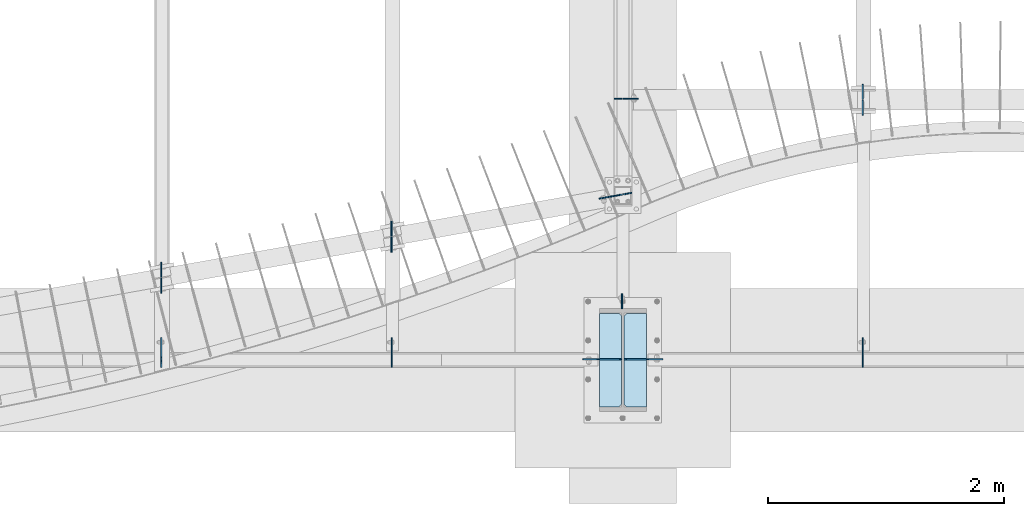
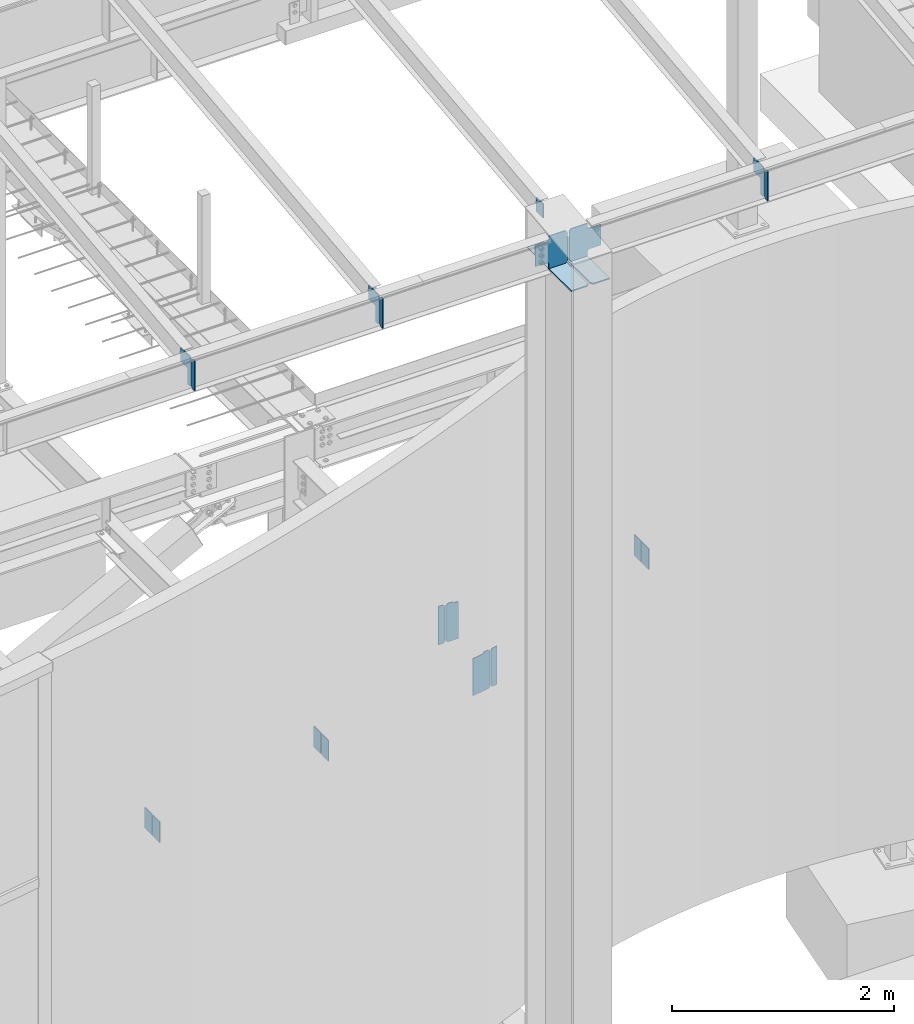
# One storey, part 986 of 1179: 21 plates, 6 elements without a shape of their own.
"""IFC2X3 building model written with IfcOpenShell, lengths in millimetres."""

import ifcopenshell
import ifcopenshell.guid

model = None  # the IFC model being written
_history = None  # IfcOwnerHistory: only IFC2X3 demands one
_inside = {}  # id of a spatial element -> (the spatial element, [elements in it])
_under = {}  # id of a project, library or spatial element -> (it, [spatial elements below it])
_declared = {}  # id of a project -> (the project, [libraries it declares])
_typed = {}  # id of a type object -> (the type object, [elements of that type])
_made_of = {}  # id of a material, layer set ... -> (it, [elements and type objects made of it])


def new_model(schema):
    """Start an empty IFC model of exactly this schema.

    Asked for "IFC4X3", IfcOpenShell would pick the latest addendum, in which some entities
    have other attributes; the version numbers below select the first issue.
    IFC2X3 requires an IfcOwnerHistory on every rooted entity: one is made here for all.
    """
    global model, _history
    if schema == "IFC4X3":
        model = ifcopenshell.file(schema_version=(4, 3, 0, 0))
    else:
        model = ifcopenshell.file(schema=schema)
    _inside.clear()
    _under.clear()
    _declared.clear()
    _typed.clear()
    _made_of.clear()
    _history = None
    if model.schema == "IFC2X3":
        org = make("IfcOrganization", Name="unknown")
        user = make(
            "IfcPersonAndOrganization",
            ThePerson=make("IfcPerson", FamilyName="unknown"),
            TheOrganization=org,
        )
        app = make(
            "IfcApplication",
            ApplicationDeveloper=org,
            Version="unknown",
            ApplicationFullName="unknown",
            ApplicationIdentifier="unknown",
        )
        _history = make(
            "IfcOwnerHistory",
            OwningUser=user,
            OwningApplication=app,
            ChangeAction="ADDED",
            CreationDate=0,
        )
    return model


def make(cls, **values):
    """One entity of the class cls with the attributes given. An attribute that is None is left unset."""
    return model.create_entity(
        cls, **{name: value for name, value in values.items() if value is not None}
    )


def rooted(cls, **values):
    """An entity with a GlobalId (a new one), such as an element, a storey or a relation."""
    return make(cls, GlobalId=ifcopenshell.guid.new(), OwnerHistory=_history, **values)


def si_unit(unit_type, name, prefix=None):
    """IfcSIUnit, for example si_unit("LENGTHUNIT", "METRE", prefix="MILLI")."""
    return make("IfcSIUnit", UnitType=unit_type, Prefix=prefix, Name=name)


def assignment(units):
    """IfcUnitAssignment: the units of a project."""
    return None if units is None else make("IfcUnitAssignment", Units=units)


def point(xyz):
    """IfcCartesianPoint."""
    return None if xyz is None else make("IfcCartesianPoint", Coordinates=xyz)


def direction(xyz):
    """IfcDirection."""
    return None if xyz is None else make("IfcDirection", DirectionRatios=xyz)


def frame(location, z_axis=None, x_axis=None):
    """IfcAxis2Placement3D, a coordinate frame: its origin and axes. An axis left out is left unset."""
    return make(
        "IfcAxis2Placement3D",
        Location=point(location),
        Axis=direction(z_axis),
        RefDirection=direction(x_axis),
    )


def origin_with_axes():
    """The frame at (0, 0, 0) with the z axis (0, 0, 1) and the x axis (1, 0, 0) written out."""
    return frame((0.0, 0.0, 0.0), z_axis=(0.0, 0.0, 1.0), x_axis=(1.0, 0.0, 0.0))


def place(relative_to, where):
    """IfcLocalPlacement: puts the frame where relative to a parent placement (None: the world)."""
    return make(
        "IfcLocalPlacement", PlacementRelTo=relative_to, RelativePlacement=where
    )


def context(
    kind, dimensions, precision=None, world=None, true_north=None, identifier=None
):
    """IfcGeometricRepresentationContext, for example the 3D "Model" context."""
    return make(
        "IfcGeometricRepresentationContext",
        ContextIdentifier=identifier,
        ContextType=kind,
        CoordinateSpaceDimension=dimensions,
        Precision=precision,
        WorldCoordinateSystem=world,
        TrueNorth=true_north,
    )


def subcontext(parent, identifier, kind, view, scale=None):
    """IfcGeometricRepresentationSubContext, for example "Body" below "Model"."""
    return make(
        "IfcGeometricRepresentationSubContext",
        ContextIdentifier=identifier,
        ContextType=kind,
        ParentContext=parent,
        TargetScale=scale,
        TargetView=view,
    )


def project(units=None, contexts=None):
    """IfcProject with its units and contexts."""
    return rooted(
        "IfcProject",
        Name="project",
        RepresentationContexts=contexts,
        UnitsInContext=assignment(units),
    )


def spatial(cls, under=None, at=None, **own):
    """A site, building, storey or space (cls), placed at a placement, below another one or the project."""
    s = rooted(cls, ObjectPlacement=at, **own)
    if under is not None:
        _under.setdefault(under.id(), (under, []))[1].append(s)
    return s


def faces_of(points, faces, orient=None, outer=None):
    """IfcFace entities. A face is a list of loops; a loop is a list of indices into points, from 0.

    orient and outer hold one flag for each loop. By default every Orientation is true, the
    first loop of a face is its IfcFaceOuterBound and the others are IfcFaceBound.
    """
    made = []
    for i, loops in enumerate(faces):
        bounds = []
        for j, loop in enumerate(loops):
            is_outer = j == 0 if outer is None else outer[i][j]
            bounds.append(
                make(
                    "IfcFaceOuterBound" if is_outer else "IfcFaceBound",
                    Bound=make("IfcPolyLoop", Polygon=[points[k] for k in loop]),
                    Orientation=True if orient is None else orient[i][j],
                )
            )
        made.append(make("IfcFace", Bounds=bounds))
    return made


def faceted_brep(points, faces, orient=None, outer=None, voids=None):
    """IfcFacetedBrep: a solid bounded by flat faces; with voids (closed shells), ...WithVoids."""
    shared = [point(p) for p in points]
    hull = make("IfcClosedShell", CfsFaces=faces_of(shared, faces, orient, outer))
    if voids is None:
        return make("IfcFacetedBrep", Outer=hull)
    return make(
        "IfcFacetedBrepWithVoids",
        Outer=hull,
        Voids=[
            make(cls, CfsFaces=faces_of(shared, fs, o, b)) for cls, fs, o, b in voids
        ],
    )


def shape(context_of_items, identifier, shape_type, items):
    """IfcShapeRepresentation: the items that make up one representation, for example the "Body"."""
    return make(
        "IfcShapeRepresentation",
        ContextOfItems=context_of_items,
        RepresentationIdentifier=identifier,
        RepresentationType=shape_type,
        Items=items,
    )


def material(Name=None, Category=None):
    """IfcMaterial."""
    return make("IfcMaterial", Name=Name, Category=Category)


def made_of(thing, what):
    """Note that an element or type object is made of a material, layer set ...; save() writes the relation."""
    if what is not None:
        _made_of.setdefault(what.id(), (what, []))[1].append(thing)
    return thing


def type_object(cls, material=None, **own):
    """A type object (cls), such as IfcWallType, which elements share."""
    return made_of(rooted(cls, **own), material)


def element(
    cls,
    number,
    at=None,
    inside=None,
    cuts=None,
    type_object=None,
    material=None,
    context=None,
    identifier="Body",
    shape_type=None,
    held_by="IfcProductDefinitionShape",
    body=None,
    shapes=None,
    **own,
):
    """One element of the class cls, such as IfcWall. Its Tag is "e" and its number.

    at: its placement. inside: the storey or other place that contains it. cuts: it is an
    opening in that element (IfcRelVoidsElement). A single representation is given by context,
    identifier, shape_type and body (its items); several are given by shapes. held_by: the class
    of the entity that holds the representations. save() writes the other relations.
    """
    e = rooted(cls, Tag="e%d" % number, ObjectPlacement=at, **own)
    if body is not None:
        shapes = [shape(context, identifier, shape_type, body)]
    if shapes is not None:
        e.Representation = make(held_by, Representations=shapes)
    if inside is not None:
        _inside.setdefault(inside.id(), (inside, []))[1].append(e)
    if cuts is not None:
        rooted(
            "IfcRelVoidsElement", RelatingBuildingElement=cuts, RelatedOpeningElement=e
        )
    if type_object is not None:
        _typed.setdefault(type_object.id(), (type_object, []))[1].append(e)
    return made_of(e, material)


def aggregate(whole, parts):
    """IfcRelAggregates: a whole, such as a stair, and the parts it consists of."""
    return rooted("IfcRelAggregates", RelatingObject=whole, RelatedObjects=parts)


def save(model, path):
    """Write the relations noted so far, then the file.

    IfcRelAggregates (storeys below a building ...), IfcRelContainedInSpatialStructure (elements
    in a storey), IfcRelDefinesByType, IfcRelAssociatesMaterial and IfcRelDeclares: one each for
    every whole, place, type object, material and project.
    """
    for whole, parts in _under.values():
        aggregate(whole, parts)
    for where, things in _inside.values():
        rooted(
            "IfcRelContainedInSpatialStructure",
            RelatedElements=things,
            RelatingStructure=where,
        )
    for kind, things in _typed.values():
        rooted("IfcRelDefinesByType", RelatedObjects=things, RelatingType=kind)
    for what, things in _made_of.values():
        rooted("IfcRelAssociatesMaterial", RelatedObjects=things, RelatingMaterial=what)
    for by, libraries in _declared.values():
        rooted("IfcRelDeclares", RelatingContext=by, RelatedDefinitions=libraries)
    model.write(path)


model = new_model("IFC2X3")

# Units and contexts
model_context = context("Model", 3, precision=1e-05, world=origin_with_axes())
body_context = subcontext(model_context, "Body", "Model", "MODEL_VIEW")
ifc_project = project(units=[si_unit("LENGTHUNIT", "METRE", prefix="MILLI"), si_unit("AREAUNIT", "SQUARE_METRE"), si_unit("VOLUMEUNIT", "CUBIC_METRE"), si_unit("MASSUNIT", "GRAM", prefix="KILO"), si_unit("TIMEUNIT", "SECOND"), si_unit("PLANEANGLEUNIT", "RADIAN"), si_unit("SOLIDANGLEUNIT", "STERADIAN"), si_unit("THERMODYNAMICTEMPERATUREUNIT", "DEGREE_CELSIUS"), si_unit("LUMINOUSINTENSITYUNIT", "LUMEN")], contexts=[model_context])

# Site, building, storey
site_placement = place(None, origin_with_axes())
site = spatial("IfcSite", under=ifc_project, at=site_placement, CompositionType="ELEMENT")
building_placement = place(site_placement, origin_with_axes())
building = spatial("IfcBuilding", under=site, at=building_placement, Name="Undefined", CompositionType="ELEMENT")
storey_placement = place(building_placement, origin_with_axes())
storey = spatial("IfcBuildingStorey", under=building, at=storey_placement, Name="Undefined", CompositionType="ELEMENT", Elevation=0.0)

# Assembly, plate
assembly_1_placement = place(storey_placement, origin_with_axes())
assembly_1 = element("IfcElementAssembly", 1, at=assembly_1_placement, inside=storey, Name="BEAM", AssemblyPlace="NOTDEFINED", PredefinedType="RIGID_FRAME")
ifc_material = material(Name="STEEL/A36")
plate_type_1 = type_object("IfcPlateType", PredefinedType="NOTDEFINED")
plate_1_placement = place(assembly_1_placement, frame((8285.16249999897, 2655.88799991608, 3408.3625), z_axis=(0.0, 0.0, 1.0), x_axis=(1.0, 0.0, 0.0)))
plate_1 = element("IfcPlate", 2, at=plate_1_placement, type_object=plate_type_1, material=ifc_material, Name="PLATE", context=body_context, shape_type="Brep", body=[
    faceted_brep([(71.4375, -4.76249999999982, 422.275), (71.4375, -4.76249999999982, 420.687499809231), (71.4375, 4.76249999999982, 420.687499809231), (71.4375, 4.76249999999982, 422.275), (72.4042299225875, -4.76249999999982, 415.827420291189), (72.4042299225875, 4.76249999999982, 415.827420291189), (75.1572438230614, -4.76249999999982, 411.707243823038), (75.1572438230614, 4.76249999999982, 411.707243823038), (79.2774202912096, -4.76249999999982, 408.954229922559), (79.2774202912096, 4.76249999999982, 408.954229922559), (84.1374998092506, -4.76249999999982, 407.987499999967), (84.1374998092506, 4.76249999999982, 407.987499999967), (126.999999992826, -4.76249999999709, 407.9875), (127.0, 4.76249999999709, 407.9875), (0.0, -4.76249999999982, 403.225000762939), (19.0499992370605, -4.76249999999982, 422.275), (19.0499992370605, 4.76249999999982, 422.275), (0.0, 4.76249999999982, 403.225000762939), (0.0, -4.76250000000073, 19.0499992370605), (0.0, 4.76250000000073, 19.0499992370605), (19.0499992370605, -4.76250000000073, 0.0), (19.0499992370605, 4.76250000000073, 0.0), (127.0, -4.76250000000073, 0.0), (127.0, 4.76250000000073, 0.0)], [[[0, 1, 2, 3]], [[4, 5, 2, 1]], [[6, 7, 5, 4]], [[8, 9, 7, 6]], [[10, 11, 9, 8]], [[12, 13, 11, 10]], [[14, 15, 16, 17]], [[18, 14, 17, 19]], [[20, 18, 19, 21]], [[22, 20, 21, 23]], [[8, 6, 4, 1, 0, 15, 14, 18, 20, 22, 12, 10]], [[16, 15, 0, 3]], [[23, 21, 19, 17, 16, 3, 2, 5, 7, 9, 11, 13]], [[22, 23, 13, 12]]]),
])

assembly_2_placement = place(storey_placement, origin_with_axes())
assembly_2 = element("IfcElementAssembly", 3, at=assembly_2_placement, inside=storey, Name="COLUMN", AssemblyPlace="NOTDEFINED", PredefinedType="RIGID_FRAME")
plate_2_placement = place(assembly_2_placement, frame((8273.25625, 876.299999999949, 9307.78440470784), z_axis=(0.0, 1.0, 0.0), x_axis=(0.0, 0.0, -1.0)))
plate_2 = element("IfcPlate", 4, at=plate_2_placement, type_object=plate_type_1, material=ifc_material, Name="PLATE", context=body_context, shape_type="Brep", body=[
    faceted_brep([(0.0, -4.76249999999709, 0.0), (0.0, -4.76249999999709, 127.0), (0.0, 4.76249999999709, 127.0), (0.0, 4.76249999999709, 0.0), (152.4, -4.76250000000073, 127.0), (152.4, 4.76250000000073, 127.0), (152.4, -4.76250000000073, 0.0), (152.4, 4.76250000000073, 0.0)], [[[0, 1, 2, 3]], [[1, 4, 5, 2]], [[4, 6, 7, 5]], [[6, 0, 3, 7]], [[5, 7, 3, 2]], [[6, 4, 1, 0]]]),
])

# Assembly, plates
assembly_3_placement = place(storey_placement, origin_with_axes())
assembly_3 = element("IfcElementAssembly", 5, at=assembly_3_placement, inside=storey, Name="BEAM", AssemblyPlace="NOTDEFINED", PredefinedType="RIGID_FRAME")
plate_3_placement = place(assembly_3_placement, frame((4360.86249837099, 1131.77012387131, 3810.0), z_axis=(0.0, -1.0, 0.0), x_axis=(0.0, 0.0, -1.0)))
plate_3 = element("IfcPlate", 6, at=plate_3_placement, type_object=plate_type_1, material=ifc_material, Name="PLATE", context=body_context, shape_type="Brep", body=[
    faceted_brep([(0.0, -4.76249999999709, 0.0), (0.0, -4.76249999999709, 127.0), (0.0, 4.76249999999709, 127.0), (0.0, 4.76249999999709, 0.0), (228.6, -4.76249999999709, 127.0), (228.6, 4.76249999999709, 127.0), (228.6, -4.76249999999709, 0.0), (228.6, 4.76249999999709, 0.0)], [[[0, 1, 2, 3]], [[1, 4, 5, 2]], [[4, 6, 7, 5]], [[6, 0, 3, 7]], [[5, 7, 3, 2]], [[6, 4, 1, 0]]]),
])
plate_4_placement = place(assembly_3_placement, frame((6316.66250203918, 1491.23864356299, 3810.0), z_axis=(0.0, 1.0, 0.0), x_axis=(0.0, 0.0, -1.0)))
plate_4 = element("IfcPlate", 7, at=plate_4_placement, type_object=plate_type_1, material=ifc_material, Name="PLATE", context=body_context, shape_type="Brep", body=[
    faceted_brep([(0.0, -4.76249999999709, 0.0), (0.0, -4.76249999999709, 127.0), (0.0, 4.76249999999709, 127.0), (0.0, 4.76249999999709, 0.0), (228.6, -4.76249999999709, 127.0), (228.6, 4.76249999999709, 127.0), (228.6, -4.76249999999709, 0.0), (228.6, 4.76249999999709, 0.0)], [[[0, 1, 2, 3]], [[1, 4, 5, 2]], [[4, 6, 7, 5]], [[6, 0, 3, 7]], [[5, 7, 3, 2]], [[6, 4, 1, 0]]]),
])
plate_5_placement = place(assembly_3_placement, frame((4360.86249856174, 1143.14009851974, 3810.0), z_axis=(0.0, 1.0, 0.0), x_axis=(0.0, 0.0, -1.0)))
plate_5 = element("IfcPlate", 8, at=plate_5_placement, type_object=plate_type_1, material=ifc_material, Name="PLATE", context=body_context, shape_type="Brep", body=[
    faceted_brep([(0.0, -4.76249999999709, 0.0), (0.0, -4.76249999999709, 127.0), (0.0, 4.76249999999709, 127.0), (0.0, 4.76249999999709, 0.0), (228.6, -4.76249999999709, 127.0), (228.6, 4.76249999999709, 127.0), (228.6, -4.76249999999709, 0.0), (228.6, 4.76249999999709, 0.0)], [[[0, 1, 2, 3]], [[1, 4, 5, 2]], [[4, 6, 7, 5]], [[6, 0, 3, 7]], [[5, 7, 3, 2]], [[6, 4, 1, 0]]]),
])

assembly_4_placement = place(storey_placement, origin_with_axes())
assembly_4 = element("IfcElementAssembly", 9, at=assembly_4_placement, inside=storey, Name="BEAM", AssemblyPlace="NOTDEFINED", PredefinedType="RIGID_FRAME")
plate_6_placement = place(assembly_4_placement, frame((10317.1625, 2651.125, 3810.0), z_axis=(0.0, 1.0, 0.0), x_axis=(0.0, 0.0, -1.0)))
plate_6 = element("IfcPlate", 10, at=plate_6_placement, type_object=plate_type_1, material=ifc_material, Name="PLATE", context=body_context, shape_type="Brep", body=[
    faceted_brep([(0.0, -4.76249999999709, 0.0), (0.0, -4.76249999999709, 127.0), (0.0, 4.76249999999709, 127.0), (0.0, 4.76249999999709, 0.0), (228.6, -4.76249999999709, 127.0), (228.6, 4.76249999999709, 127.0), (228.6, -4.76249999999709, 0.0), (228.6, 4.76249999999709, 0.0)], [[[0, 1, 2, 3]], [[1, 4, 5, 2]], [[4, 6, 7, 5]], [[6, 0, 3, 7]], [[5, 7, 3, 2]], [[6, 4, 1, 0]]]),
])
plate_7_placement = place(assembly_4_placement, frame((10317.1625000023, 2644.775, 3810.0), z_axis=(0.0, -1.0, 0.0), x_axis=(0.0, 0.0, -1.0)))
plate_7 = element("IfcPlate", 11, at=plate_7_placement, type_object=plate_type_1, material=ifc_material, Name="PLATE", context=body_context, shape_type="Brep", body=[
    faceted_brep([(0.0, -4.76249999999709, 0.0), (0.0, -4.76249999999709, 127.0), (0.0, 4.76249999999709, 127.0), (0.0, 4.76249999999709, 0.0), (228.6, -4.76249999999709, 127.0), (228.6, 4.76249999999709, 127.0), (228.6, -4.76249999999709, 0.0), (228.6, 4.76249999999709, 0.0)], [[[0, 1, 2, 3]], [[1, 4, 5, 2]], [[4, 6, 7, 5]], [[6, 0, 3, 7]], [[5, 7, 3, 2]], [[6, 4, 1, 0]]]),
])
aggregate(assembly_4, [plate_6, plate_7])

# Plate
plate_8_placement = place(assembly_3_placement, frame((6316.66250194783, 1479.86866893229, 3810.0), z_axis=(0.0, -1.0, 0.0), x_axis=(0.0, 0.0, -1.0)))
plate_8 = element("IfcPlate", 12, at=plate_8_placement, type_object=plate_type_1, material=ifc_material, Name="PLATE", context=body_context, shape_type="Brep", body=[
    faceted_brep([(0.0, -4.76249999999709, 0.0), (0.0, -4.76249999999709, 127.0), (0.0, 4.76249999999709, 127.0), (0.0, 4.76249999999709, 0.0), (228.6, -4.76249999999709, 127.0), (228.6, 4.76249999999709, 127.0), (228.6, -4.76249999999709, 0.0), (228.6, 4.76249999999709, 0.0)], [[[0, 1, 2, 3]], [[1, 4, 5, 2]], [[4, 6, 7, 5]], [[6, 0, 3, 7]], [[5, 7, 3, 2]], [[6, 4, 1, 0]]]),
])

aggregate(assembly_3, [plate_3, plate_4, plate_5, plate_8])

# Assembly, plate
assembly_5_placement = place(storey_placement, origin_with_axes())
assembly_5 = element("IfcElementAssembly", 13, at=assembly_5_placement, inside=storey, Name="BEAM", AssemblyPlace="NOTDEFINED", PredefinedType="RIGID_FRAME")
plate_type_2 = type_object("IfcPlateType", PredefinedType="NOTDEFINED")
plate_9_placement = place(assembly_5_placement, frame((10317.9557500839, 434.97499988271, 8925.52031305008), z_axis=(0.0, 0.0, 1.0), x_axis=(0.0, -1.0, 0.0)))
plate_9 = element("IfcPlate", 14, at=plate_9_placement, type_object=plate_type_2, material=ifc_material, Name="PLATE", context=body_context, shape_type="Brep", body=[
    faceted_brep([(0.0, -4.76250000000073, 22.2250003814697), (0.0, -4.76250000000073, 307.974999618531), (0.0, 4.76250000000073, 307.974999618531), (0.0, 4.76250000000073, 22.2250003814697), (22.2250003814697, -4.76250000000073, 330.200000000001), (22.2250003814697, 4.76250000000073, 330.200000000001), (58.7375, -4.76250000000073, 330.200000000001), (58.7375, 4.76250000000073, 330.200000000001), (58.7375, -4.76250000000073, 0.0), (58.7375, 4.76250000000073, 0.0), (22.2250003814697, -4.76250000000073, 0.0), (22.2250003814697, 4.76250000000073, 0.0)], [[[0, 1, 2, 3]], [[1, 4, 5, 2]], [[4, 6, 7, 5]], [[6, 8, 9, 7]], [[8, 10, 11, 9]], [[10, 0, 3, 11]], [[5, 7, 9, 11, 3, 2]], [[10, 8, 6, 4, 1, 0]]]),
])

# Assembly, plates
assembly_6_placement = place(storey_placement, origin_with_axes())
assembly_6 = element("IfcElementAssembly", 15, at=assembly_6_placement, inside=storey, Name="BEAM", AssemblyPlace="NOTDEFINED", PredefinedType="RIGID_FRAME")
plate_10_placement = place(assembly_6_placement, frame((6317.45575008393, 434.97499988271, 8925.52031305008), z_axis=(0.0, 0.0, 1.0), x_axis=(0.0, -1.0, 0.0)))
plate_10 = element("IfcPlate", 16, at=plate_10_placement, type_object=plate_type_2, material=ifc_material, Name="PLATE", context=body_context, shape_type="Brep", body=[
    faceted_brep([(0.0, -4.76250000000073, 22.2250003814697), (0.0, -4.76250000000073, 307.974999618531), (0.0, 4.76250000000073, 307.974999618531), (0.0, 4.76250000000073, 22.2250003814697), (22.2250003814697, -4.76250000000073, 330.200000000001), (22.2250003814697, 4.76250000000073, 330.200000000001), (58.7375, -4.76250000000073, 330.200000000001), (58.7375, 4.76250000000073, 330.200000000001), (58.7375, -4.76250000000073, 0.0), (58.7375, 4.76250000000073, 0.0), (22.2250003814697, -4.76250000000073, 0.0), (22.2250003814697, 4.76250000000073, 0.0)], [[[0, 1, 2, 3]], [[1, 4, 5, 2]], [[4, 6, 7, 5]], [[6, 8, 9, 7]], [[8, 10, 11, 9]], [[10, 0, 3, 11]], [[5, 7, 9, 11, 3, 2]], [[10, 8, 6, 4, 1, 0]]]),
])
plate_11_placement = place(assembly_6_placement, frame((4361.65575008393, 434.97499988271, 8925.52031305008), z_axis=(0.0, 0.0, 1.0), x_axis=(0.0, -1.0, 0.0)))
plate_11 = element("IfcPlate", 17, at=plate_11_placement, type_object=plate_type_2, material=ifc_material, Name="PLATE", context=body_context, shape_type="Brep", body=[
    faceted_brep([(0.0, -4.76250000000073, 22.2250003814697), (0.0, -4.76250000000073, 307.974999618531), (0.0, 4.76250000000073, 307.974999618531), (0.0, 4.76250000000073, 22.2250003814697), (22.2250003814697, -4.76250000000073, 330.200000000001), (22.2250003814697, 4.76250000000073, 330.200000000001), (58.7375, -4.76250000000073, 330.200000000001), (58.7375, 4.76250000000073, 330.200000000001), (58.7375, -4.76250000000073, 0.0), (58.7375, 4.76250000000073, 0.0), (22.2250003814697, -4.76250000000073, 0.0), (22.2250003814697, 4.76250000000073, 0.0)], [[[0, 1, 2, 3]], [[1, 4, 5, 2]], [[4, 6, 7, 5]], [[6, 8, 9, 7]], [[8, 10, 11, 9]], [[10, 0, 3, 11]], [[5, 7, 9, 11, 3, 2]], [[10, 8, 6, 4, 1, 0]]]),
])

# Plate
plate_type_3 = type_object("IfcPlateType", PredefinedType="NOTDEFINED")
plate_12_placement = place(assembly_5_placement, frame((10317.9557500839, 441.324999882713, 8947.74531305003), z_axis=(0.0, 0.707106781186542, 0.707106781186553), x_axis=(0.0, 0.707106781186553, -0.707106781186542)))
plate_12 = element("IfcPlate", 18, at=plate_12_placement, type_object=plate_type_3, material=ifc_material, Name="PLATE", context=body_context, shape_type="Brep", body=[
    faceted_brep([(0.0, -4.76249999999709, 0.0), (-202.055762724124, -4.76250000000073, 202.055762724127), (-202.055762724124, 4.76250000000073, 202.055762724127), (0.0, 4.76249999999709, 0.0), (-202.05576272413, -4.76250000000073, 233.486659147874), (-202.05576272413, 4.76250000000073, 233.486659147874), (-85.2817411997539, -4.76250000000073, 350.199296771269), (-85.2817411997539, 4.76250000000073, 350.199296771269), (22.4813322531099, -4.76250000000073, 242.436223318402), (22.4813322531099, 4.76250000000073, 242.436223318402), (-58.3409729713785, -4.76250000000073, 161.613918093915), (-58.3409729713785, 4.76250000000073, 161.613918093915), (-61.093986871856, -4.76250000000073, 157.493741625763), (-61.093986871856, 4.76250000000073, 157.493741625763), (-62.0607167944436, -4.76250000000073, 152.633662107716), (-62.0607167944436, 4.76250000000073, 152.633662107716), (-61.0939868718551, -4.76250000000073, 147.773582589671), (-61.0939868718551, 4.76250000000073, 147.773582589671), (-58.3409729713767, -4.76250000000073, 143.653406121516), (-58.3409729713767, 4.76250000000073, 143.653406121516), (58.3716647869414, -4.76250000000073, 26.9407683631916), (58.3716647869414, 4.76250000000073, 26.9407683631916), (31.4308964237443, -4.76250000000073, -5.45696821063757e-12), (31.4308964237443, 4.76250000000073, -5.45696821063757e-12)], [[[0, 1, 2, 3]], [[1, 4, 5, 2]], [[4, 6, 7, 5]], [[6, 8, 9, 7]], [[8, 10, 11, 9]], [[10, 12, 13, 11]], [[12, 14, 15, 13]], [[14, 16, 17, 15]], [[16, 18, 19, 17]], [[18, 20, 21, 19]], [[20, 22, 23, 21]], [[22, 0, 3, 23]], [[5, 7, 9, 11, 13, 15, 17, 19, 21, 23, 3, 2]], [[22, 20, 18, 16, 14, 12, 10, 8, 6, 4, 1, 0]]]),
])

aggregate(assembly_5, [plate_9, plate_12])

plate_13_placement = place(assembly_6_placement, frame((6317.45575008393, 441.324999882713, 8947.74531305003), z_axis=(0.0, 0.707106781186542, 0.707106781186553), x_axis=(0.0, 0.707106781186553, -0.707106781186542)))
plate_13 = element("IfcPlate", 19, at=plate_13_placement, type_object=plate_type_3, material=ifc_material, Name="PLATE", context=body_context, shape_type="Brep", body=[
    faceted_brep([(0.0, -4.76249999999709, 0.0), (-202.055762724124, -4.76250000000073, 202.055762724127), (-202.055762724124, 4.76250000000073, 202.055762724127), (0.0, 4.76249999999709, 0.0), (-202.05576272413, -4.76250000000073, 233.486659147874), (-202.05576272413, 4.76250000000073, 233.486659147874), (-85.2817411997539, -4.76250000000073, 350.199296771269), (-85.2817411997539, 4.76250000000073, 350.199296771269), (22.4813322531099, -4.76250000000073, 242.436223318402), (22.4813322531099, 4.76250000000073, 242.436223318402), (-58.3409729713785, -4.76250000000073, 161.613918093915), (-58.3409729713785, 4.76250000000073, 161.613918093915), (-61.093986871856, -4.76250000000073, 157.493741625763), (-61.093986871856, 4.76250000000073, 157.493741625763), (-62.0607167944436, -4.76250000000073, 152.633662107716), (-62.0607167944436, 4.76250000000073, 152.633662107716), (-61.0939868718551, -4.76250000000073, 147.773582589671), (-61.0939868718551, 4.76250000000073, 147.773582589671), (-58.3409729713767, -4.76250000000073, 143.653406121516), (-58.3409729713767, 4.76250000000073, 143.653406121516), (58.3716647869414, -4.76250000000073, 26.9407683631916), (58.3716647869414, 4.76250000000073, 26.9407683631916), (31.4308964237443, -4.76250000000073, -5.45696821063757e-12), (31.4308964237443, 4.76250000000073, -5.45696821063757e-12)], [[[0, 1, 2, 3]], [[1, 4, 5, 2]], [[4, 6, 7, 5]], [[6, 8, 9, 7]], [[8, 10, 11, 9]], [[10, 12, 13, 11]], [[12, 14, 15, 13]], [[14, 16, 17, 15]], [[16, 18, 19, 17]], [[18, 20, 21, 19]], [[20, 22, 23, 21]], [[22, 0, 3, 23]], [[5, 7, 9, 11, 13, 15, 17, 19, 21, 23, 3, 2]], [[22, 20, 18, 16, 14, 12, 10, 8, 6, 4, 1, 0]]]),
])

plate_14_placement = place(assembly_6_placement, frame((4361.65575008393, 441.324999882713, 8947.74531305003), z_axis=(0.0, 0.707106781186542, 0.707106781186553), x_axis=(0.0, 0.707106781186553, -0.707106781186542)))
plate_14 = element("IfcPlate", 20, at=plate_14_placement, type_object=plate_type_3, material=ifc_material, Name="PLATE", context=body_context, shape_type="Brep", body=[
    faceted_brep([(0.0, -4.76249999999709, 0.0), (-202.055762724124, -4.76250000000073, 202.055762724127), (-202.055762724124, 4.76250000000073, 202.055762724127), (0.0, 4.76249999999709, 0.0), (-202.05576272413, -4.76250000000073, 233.486659147874), (-202.05576272413, 4.76250000000073, 233.486659147874), (-85.2817411997539, -4.76250000000073, 350.199296771269), (-85.2817411997539, 4.76250000000073, 350.199296771269), (22.4813322531099, -4.76250000000073, 242.436223318402), (22.4813322531099, 4.76250000000073, 242.436223318402), (-58.3409729713785, -4.76250000000073, 161.613918093915), (-58.3409729713785, 4.76250000000073, 161.613918093915), (-61.093986871856, -4.76250000000073, 157.493741625763), (-61.093986871856, 4.76250000000073, 157.493741625763), (-62.0607167944436, -4.76250000000073, 152.633662107716), (-62.0607167944436, 4.76250000000073, 152.633662107716), (-61.0939868718551, -4.76250000000073, 147.773582589671), (-61.0939868718551, 4.76250000000073, 147.773582589671), (-58.3409729713767, -4.76250000000073, 143.653406121516), (-58.3409729713767, 4.76250000000073, 143.653406121516), (58.3716647869414, -4.76250000000073, 26.9407683631916), (58.3716647869414, 4.76250000000073, 26.9407683631916), (31.4308964237443, -4.76250000000073, -5.45696821063757e-12), (31.4308964237443, 4.76250000000073, -5.45696821063757e-12)], [[[0, 1, 2, 3]], [[1, 4, 5, 2]], [[4, 6, 7, 5]], [[6, 8, 9, 7]], [[8, 10, 11, 9]], [[10, 12, 13, 11]], [[12, 14, 15, 13]], [[14, 16, 17, 15]], [[16, 18, 19, 17]], [[18, 20, 21, 19]], [[20, 22, 23, 21]], [[22, 0, 3, 23]], [[5, 7, 9, 11, 13, 15, 17, 19, 21, 23, 3, 2]], [[22, 20, 18, 16, 14, 12, 10, 8, 6, 4, 1, 0]]]),
])

aggregate(assembly_6, [plate_10, plate_13, plate_11, plate_14])

plate_type_4 = type_object("IfcPlateType", PredefinedType="NOTDEFINED")
plate_15_placement = place(assembly_1_placement, frame((8275.63749999897, 2655.88799991608, 3408.3625), z_axis=(0.0, 0.0, 1.0), x_axis=(-1.0, 0.0, 0.0)))
plate_15 = element("IfcPlate", 21, at=plate_15_placement, type_object=plate_type_4, material=ifc_material, Name="PLATE", context=body_context, shape_type="Brep", body=[
    faceted_brep([(0.0, -4.76250000000073, 19.0499992370605), (0.0, -4.76249999999982, 403.225000762939), (0.0, 4.76249999999982, 403.225000762939), (0.0, 4.76250000000073, 19.0499992370605), (19.0499992370605, -4.76249999999982, 422.275), (19.0499992370605, 4.76249999999982, 422.275), (69.8499999999985, -4.76249999999982, 422.275), (69.8499999999985, 4.76249999999982, 422.275), (69.8499999999985, -4.76249999999982, 0.0), (69.8499999999985, 4.76249999999982, 0.0), (19.0499992370605, -4.76250000000073, 0.0), (19.0499992370605, 4.76250000000073, 0.0)], [[[0, 1, 2, 3]], [[1, 4, 5, 2]], [[4, 6, 7, 5]], [[6, 8, 9, 7]], [[8, 10, 11, 9]], [[10, 0, 3, 11]], [[5, 7, 9, 11, 3, 2]], [[10, 8, 6, 4, 1, 0]]]),
])

plate_16_placement = place(assembly_1_placement, frame((8285.99693999739, 1845.73629370428, 3408.3625), z_axis=(0.0, 0.0, 1.0), x_axis=(0.984527722010802, 0.175228892001923, 0.0)))
plate_16 = element("IfcPlate", 22, at=plate_16_placement, type_object=plate_type_4, material=ifc_material, Name="PLATE", context=body_context, shape_type="Brep", body=[
    faceted_brep([(-1.81898940354586e-12, -4.76249999999936, 15.875), (0.0, -4.76249999999709, 406.400000762939), (0.0, 4.76249999999709, 406.400000762939), (1.81898940354586e-12, 4.76249999999936, 15.875), (15.8749999999873, -4.76249999999675, 422.274993896484), (15.8749999999909, 4.76250000000312, 422.274993896484), (69.8499999999985, -4.76249999999982, 422.275), (69.8499999999985, 4.76249999999982, 422.275), (69.8499999999985, -4.76249999999982, 0.0), (69.8499999999985, 4.76249999999982, 0.0), (15.8749999999891, -4.76249999999845, 0.0), (15.8749999999945, 4.76250000000027, 0.0)], [[[0, 1, 2, 3]], [[1, 4, 5, 2]], [[4, 6, 7, 5]], [[6, 8, 9, 7]], [[8, 10, 11, 9]], [[10, 0, 3, 11]], [[5, 7, 9, 11, 3, 2]], [[10, 8, 6, 4, 1, 0]]]),
])

plate_type_5 = type_object("IfcPlateType", PredefinedType="NOTDEFINED")
plate_17_placement = place(assembly_2_placement, frame((8480.425, 41.275, 8922.34531305009), z_axis=(0.0, 1.0, 0.0), x_axis=(-1.0, 0.0, 0.0)))
plate_17 = element("IfcPlate", 23, at=plate_17_placement, type_object=plate_type_5, material=ifc_material, Name="PLATE", context=body_context, shape_type="Brep", body=[
    faceted_brep([(0.0, -6.34999999999854, 0.0), (0.0, -6.35000000000036, 793.75), (0.0, 6.35000000000036, 793.75), (0.0, 6.34999999999854, 0.0), (166.687499618532, -6.35000000000036, 793.75), (166.687499618532, 6.35000000000036, 793.75), (188.912500000002, -6.35000000000036, 771.52499961853), (188.912500000002, 6.35000000000036, 771.52499961853), (188.912500000002, -6.35000000000036, 22.2250003814697), (188.912500000002, 6.35000000000036, 22.2250003814697), (166.687499618532, -6.35000000000036, 0.0), (166.687499618532, 6.35000000000036, 0.0)], [[[0, 1, 2, 3]], [[1, 4, 5, 2]], [[4, 6, 7, 5]], [[6, 8, 9, 7]], [[8, 10, 11, 9]], [[10, 0, 3, 11]], [[5, 7, 9, 11, 3, 2]], [[10, 8, 6, 4, 1, 0]]]),
])

plate_18_placement = place(assembly_2_placement, frame((8080.375, 835.025, 8922.34531305009), z_axis=(0.0, -1.0, 0.0), x_axis=(1.0, 0.0, 0.0)))
plate_18 = element("IfcPlate", 24, at=plate_18_placement, type_object=plate_type_5, material=ifc_material, Name="PLATE", context=body_context, shape_type="Brep", body=[
    faceted_brep([(0.0, -6.34999999999854, 0.0), (0.0, -6.35000000000036, 793.75), (0.0, 6.35000000000036, 793.75), (0.0, 6.34999999999854, 0.0), (166.687499618532, -6.35000000000036, 793.75), (166.687499618532, 6.35000000000036, 793.75), (188.912500000002, -6.35000000000036, 771.52499961853), (188.912500000002, 6.35000000000036, 771.52499961853), (188.912500000002, -6.35000000000036, 22.2250003814697), (188.912500000002, 6.35000000000036, 22.2250003814697), (166.687499618532, -6.35000000000036, 0.0), (166.687499618532, 6.35000000000036, 0.0)], [[[0, 1, 2, 3]], [[1, 4, 5, 2]], [[4, 6, 7, 5]], [[6, 8, 9, 7]], [[8, 10, 11, 9]], [[10, 0, 3, 11]], [[5, 7, 9, 11, 3, 2]], [[10, 8, 6, 4, 1, 0]]]),
])

plate_type_6 = type_object("IfcPlateType", PredefinedType="NOTDEFINED")
plate_19_placement = place(assembly_2_placement, frame((8291.5125, 446.08749988271, 8947.74531305009), z_axis=(0.707106781186573, 0.0, 0.707106781186522), x_axis=(0.707106781186522, 0.0, -0.707106781186573)))
plate_19 = element("IfcPlate", 25, at=plate_19_placement, type_object=plate_type_6, material=ifc_material, Name="PLATE", context=body_context, shape_type="Brep", body=[
    faceted_brep([(0.0, -4.76249999999709, 0.0), (-226.470816375611, -4.76249999999999, 226.470816375618), (-226.470816375611, 4.76249999999999, 226.470816375618), (0.0, 4.76249999999709, 0.0), (-226.470816375654, -4.76249999999999, 253.411584738797), (-226.470816375654, 4.76249999999999, 253.411584738797), (-106.359890756637, -4.76249999999999, 373.52251035781), (-106.359890756637, 4.76249999999999, 373.52251035781), (-81.9448368353978, -4.76249999999999, 349.107456436569), (-81.9448368353978, 4.76249999999999, 349.107456436569), (-73.7044838990896, -4.76249999999999, 343.601428635614), (-73.7044838990896, 4.76249999999999, 343.601428635614), (-63.9843248629977, -4.76249999999999, 341.667968790437), (-63.9843248629977, 4.76249999999999, 341.667968790437), (-54.2641658269058, -4.76249999999999, 343.601428635612), (-54.2641658269058, 4.76249999999999, 343.601428635612), (-46.0238128905976, -4.76249999999999, 349.107456436567), (-46.0238128905976, 4.76249999999999, 349.107456436567), (34.798492468527, -4.76249999999999, 429.929761795689), (34.798492468527, 4.76249999999999, 429.929761795689), (196.443102647823, -4.76249999999999, 268.285151616388), (196.443102647823, 4.76249999999999, 268.285151616388), (115.620797288699, -4.76249999999999, 187.462846257265), (115.620797288699, 4.76249999999999, 187.462846257265), (110.114769487744, -4.76249999999999, 179.222493320958), (110.114769487744, 4.76249999999999, 179.222493320958), (108.181309642569, -4.76249999999999, 169.502334284865), (108.181309642569, 4.76249999999999, 169.502334284865), (110.114769487745, -4.76249999999999, 159.782175248773), (110.114769487745, 4.76249999999999, 159.782175248773), (115.620797288702, -4.76249999999999, 151.541822312464), (115.620797288702, 4.76249999999999, 151.541822312464), (147.051693982197, -4.76249999999999, 120.110925618969), (147.051693982197, 4.76249999999999, 120.110925618969), (26.9407683631525, -4.76249999999709, -6.18456397205591e-11), (26.9407683631525, 4.76249999999709, -6.18456397205591e-11)], [[[0, 1, 2, 3]], [[1, 4, 5, 2]], [[4, 6, 7, 5]], [[6, 8, 9, 7]], [[8, 10, 11, 9]], [[10, 12, 13, 11]], [[12, 14, 15, 13]], [[14, 16, 17, 15]], [[16, 18, 19, 17]], [[18, 20, 21, 19]], [[20, 22, 23, 21]], [[22, 24, 25, 23]], [[24, 26, 27, 25]], [[26, 28, 29, 27]], [[28, 30, 31, 29]], [[30, 32, 33, 31]], [[32, 34, 35, 33]], [[34, 0, 3, 35]], [[5, 7, 9, 11, 13, 15, 17, 19, 21, 23, 25, 27, 29, 31, 33, 35, 3, 2]], [[34, 32, 30, 28, 26, 24, 22, 20, 18, 16, 14, 12, 10, 8, 6, 4, 1, 0]]]),
])

plate_20_placement = place(assembly_2_placement, frame((8269.2875, 446.08749988271, 8947.74531305009), z_axis=(-0.707106781186532, 0.0, 0.707106781186563), x_axis=(-0.707106781186564, 0.0, -0.707106781186531)))
plate_20 = element("IfcPlate", 26, at=plate_20_placement, type_object=plate_type_6, material=ifc_material, Name="PLATE", context=body_context, shape_type="Brep", body=[
    faceted_brep([(0.0, -4.76249999999709, 0.0), (-226.470816375611, -4.76249999999999, 226.470816375618), (-226.470816375611, 4.76249999999999, 226.470816375618), (0.0, 4.76249999999709, 0.0), (-226.470816375654, -4.76249999999999, 253.411584738797), (-226.470816375654, 4.76249999999999, 253.411584738797), (-106.359890756637, -4.76249999999999, 373.52251035781), (-106.359890756637, 4.76249999999999, 373.52251035781), (-81.9448368353978, -4.76249999999999, 349.107456436569), (-81.9448368353978, 4.76249999999999, 349.107456436569), (-73.7044838990896, -4.76249999999999, 343.601428635614), (-73.7044838990896, 4.76249999999999, 343.601428635614), (-63.9843248629977, -4.76249999999999, 341.667968790437), (-63.9843248629977, 4.76249999999999, 341.667968790437), (-54.2641658269058, -4.76249999999999, 343.601428635612), (-54.2641658269058, 4.76249999999999, 343.601428635612), (-46.0238128905976, -4.76249999999999, 349.107456436567), (-46.0238128905976, 4.76249999999999, 349.107456436567), (34.798492468527, -4.76249999999999, 429.929761795689), (34.798492468527, 4.76249999999999, 429.929761795689), (196.443102647823, -4.76249999999999, 268.285151616388), (196.443102647823, 4.76249999999999, 268.285151616388), (115.620797288699, -4.76249999999999, 187.462846257265), (115.620797288699, 4.76249999999999, 187.462846257265), (110.114769487744, -4.76249999999999, 179.222493320958), (110.114769487744, 4.76249999999999, 179.222493320958), (108.181309642569, -4.76249999999999, 169.502334284865), (108.181309642569, 4.76249999999999, 169.502334284865), (110.114769487745, -4.76249999999999, 159.782175248773), (110.114769487745, 4.76249999999999, 159.782175248773), (115.620797288702, -4.76249999999999, 151.541822312464), (115.620797288702, 4.76249999999999, 151.541822312464), (147.051693982197, -4.76249999999999, 120.110925618969), (147.051693982197, 4.76249999999999, 120.110925618969), (26.9407683631525, -4.76249999999709, -6.18456397205591e-11), (26.9407683631525, 4.76249999999709, -6.18456397205591e-11)], [[[0, 1, 2, 3]], [[1, 4, 5, 2]], [[4, 6, 7, 5]], [[6, 8, 9, 7]], [[8, 10, 11, 9]], [[10, 12, 13, 11]], [[12, 14, 15, 13]], [[14, 16, 17, 15]], [[16, 18, 19, 17]], [[18, 20, 21, 19]], [[20, 22, 23, 21]], [[22, 24, 25, 23]], [[24, 26, 27, 25]], [[26, 28, 29, 27]], [[28, 30, 31, 29]], [[30, 32, 33, 31]], [[32, 34, 35, 33]], [[34, 0, 3, 35]], [[5, 7, 9, 11, 13, 15, 17, 19, 21, 23, 25, 27, 29, 31, 33, 35, 3, 2]], [[34, 32, 30, 28, 26, 24, 22, 20, 18, 16, 14, 12, 10, 8, 6, 4, 1, 0]]]),
])

aggregate(assembly_2, [plate_2, plate_17, plate_19, plate_18, plate_20])

plate_type_7 = type_object("IfcPlateType", PredefinedType="NOTDEFINED")
plate_21_placement = place(assembly_1_placement, frame((8274.80288480108, 1843.74394564995, 3408.3625), z_axis=(0.0, 0.0, 1.0), x_axis=(-0.984527722010802, -0.175228892001923, 0.0)))
plate_21 = element("IfcPlate", 27, at=plate_21_placement, type_object=plate_type_7, material=ifc_material, Name="PLATE", context=body_context, shape_type="Brep", body=[
    faceted_brep([(70.8648461799839, -4.76249999998714, 422.275), (70.8648461799767, -4.76249999998714, 420.687499809266), (70.8648461706052, 4.76250000001272, 420.687499809266), (70.8648461706071, 4.76250000001272, 422.275), (71.8315761025624, -4.76249999998714, 415.82742029122), (71.831576093191, 4.76250000001272, 415.82742029122), (74.5845900030399, -4.76249999998646, 411.707243823066), (74.5845899936685, 4.7625000000134, 411.707243823066), (78.7047664711936, -4.76249999998601, 408.954229922588), (78.7047664618221, 4.76250000001386, 408.954229922588), (83.5648459892363, -4.76249999998464, 407.9875), (83.5648459798667, 4.762500000015, 407.9875), (200.024999999632, -4.76249999996327, 407.9875), (200.024999999636, 4.76250000003637, 407.9875), (0.0, -4.76249999999709, 406.400000762939), (15.8749999999873, -4.76249999999675, 422.274993896484), (15.8749999999909, 4.76250000000312, 422.274993896484), (0.0, 4.76249999999709, 406.400000762939), (-1.81898940354586e-12, -4.76249999999936, 15.875), (1.81898940354586e-12, 4.76249999999936, 15.875), (15.8749999999891, -4.76249999999845, 0.0), (15.8749999999945, 4.76250000000027, 0.0), (200.024999999632, -4.76249999996327, 0.0), (200.024999999636, 4.76250000003637, 0.0)], [[[0, 1, 2, 3]], [[4, 5, 2, 1]], [[6, 7, 5, 4]], [[8, 9, 7, 6]], [[10, 11, 9, 8]], [[12, 13, 11, 10]], [[14, 15, 16, 17]], [[18, 14, 17, 19]], [[20, 18, 19, 21]], [[22, 20, 21, 23]], [[8, 6, 4, 1, 0, 15, 14, 18, 20, 22, 12, 10]], [[16, 15, 0, 3]], [[23, 21, 19, 17, 16, 3, 2, 5, 7, 9, 11, 13]], [[22, 23, 13, 12]]]),
])

aggregate(assembly_1, [plate_15, plate_1, plate_16, plate_21])

save(model, "model.ifc")
